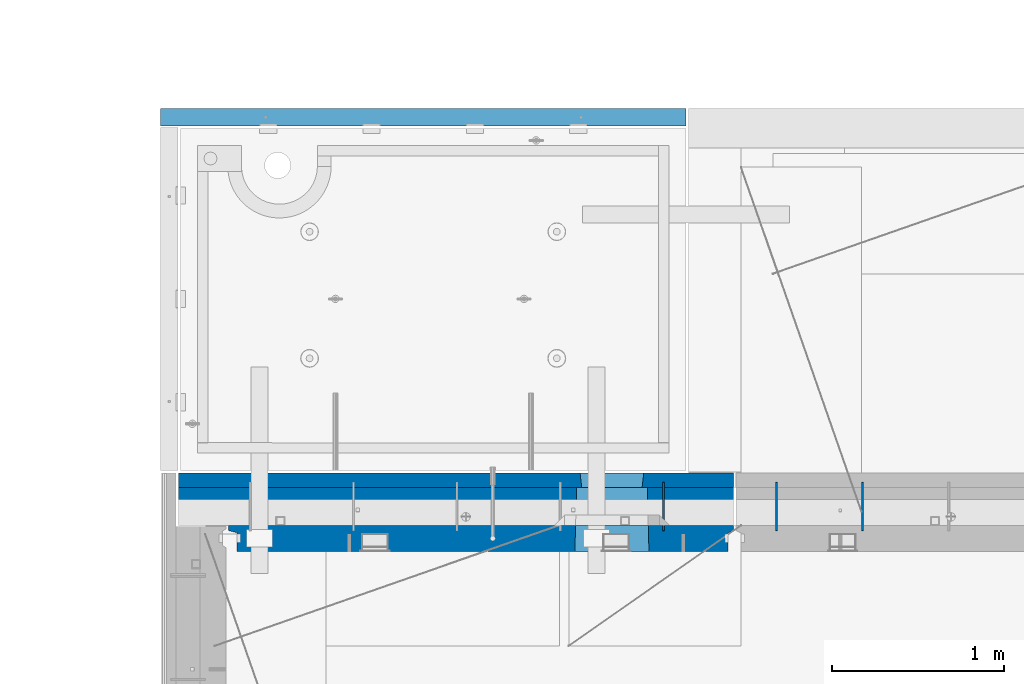
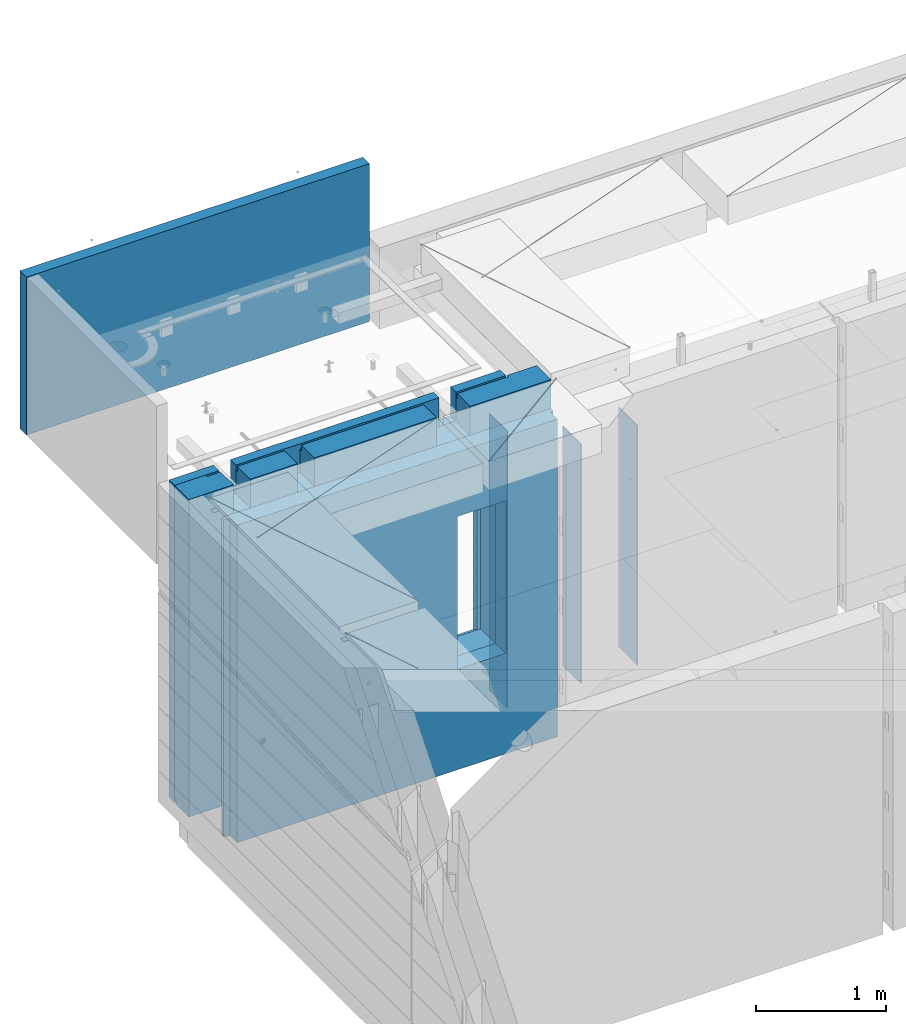
# One storey, part 215 of 325: 7 walls, 3 elements without a shape of their own.
"""IFC2X3 building model written with IfcOpenShell, lengths in millimetres."""

from ifc_helpers import new_model, si_unit, frame, origin_with_axes, place, context, subcontext, project, spatial, faceted_brep, material, type_object, element, aggregate, save


model = new_model("IFC2X3")

# Units and contexts
model_context = context("Model", 3, precision=1e-05, world=origin_with_axes())
body_context = subcontext(model_context, "Body", "Model", "MODEL_VIEW")
ifc_project = project(units=[si_unit("LENGTHUNIT", "METRE", prefix="MILLI"), si_unit("AREAUNIT", "SQUARE_METRE"), si_unit("VOLUMEUNIT", "CUBIC_METRE"), si_unit("MASSUNIT", "GRAM", prefix="KILO"), si_unit("TIMEUNIT", "SECOND"), si_unit("PLANEANGLEUNIT", "RADIAN"), si_unit("SOLIDANGLEUNIT", "STERADIAN"), si_unit("THERMODYNAMICTEMPERATUREUNIT", "DEGREE_CELSIUS"), si_unit("LUMINOUSINTENSITYUNIT", "LUMEN")], contexts=[model_context])

# Site, building, storey
site_placement = place(None, origin_with_axes())
site = spatial("IfcSite", under=ifc_project, at=site_placement, CompositionType="ELEMENT")
building_placement = place(site_placement, origin_with_axes())
building = spatial("IfcBuilding", under=site, at=building_placement, CompositionType="ELEMENT")
storey_placement = place(building_placement, origin_with_axes())
storey = spatial("IfcBuildingStorey", under=building, at=storey_placement, Name="1", CompositionType="ELEMENT", Elevation=0.0)

# Assembly, walls
assembly_1_placement = place(storey_placement, origin_with_axes())
assembly_1 = element("IfcElementAssembly", 1, at=assembly_1_placement, inside=storey, AssemblyPlace="NOTDEFINED", PredefinedType="REINFORCEMENT_UNIT")
ifc_material_1 = material(Name="Undefined")
wall_type_1 = type_object("IfcWallType", PredefinedType="NOTDEFINED")
wall_1_placement = place(assembly_1_placement, frame((10540.0002441406, 20549.9951872276, 83115.0), z_axis=(0.0, 0.0, 1.0), x_axis=(0.0, 1.0, 0.0)))
wall_1 = element("IfcWall", 2, at=wall_1_placement, type_object=wall_type_1, material=ifc_material_1, Name="(PD)", context=body_context, shape_type="Brep", body=[
    faceted_brep([(0.0, 5.0, -1300.0), (0.0, 5.0, 1300.0), (280.0, 5.0, 1300.0), (280.0, 5.0, -1300.0), (0.0, -5.0, 1300.0), (280.0, -5.0, 1300.0), (0.0, -5.0, -1300.0), (280.0, -5.0, -1300.0)], [[[0, 1, 2, 3]], [[1, 4, 5, 2]], [[4, 6, 7, 5]], [[6, 0, 3, 7]], [[5, 7, 3, 2]], [[6, 4, 1, 0]]]),
])
ifc_material_2 = material(Name="COS5gt")
wall_type_2 = type_object("IfcWallType", PredefinedType="NOTDEFINED")
wall_2_placement = place(assembly_1_placement, frame((7725.0, 20689.9951872276, 83247.5), z_axis=(0.0, 0.0, 1.0), x_axis=(1.0, 0.0, 0.0)))
wall_2 = element("IfcWall", 3, at=wall_2_placement, type_object=wall_type_2, material=ifc_material_2, context=body_context, shape_type="Brep", body=[
    faceted_brep([(964.999999999998, 110.0, 1442.5), (964.999999999998, 90.0, 1442.5), (964.999999999998, 90.0, 1492.5), (964.999999999998, -110.0, 1492.5), (964.999999999998, -110.000000000007, 1222.5), (964.999999999998, 109.999999999993, 1222.5), (1115.0, -110.000000000007, 1222.5), (1115.0, 109.999999999993, 1222.5), (1115.0, 110.0, 1442.5), (1115.0, -110.0, 1492.5), (1115.0, 90.0, 1492.5), (1115.0, 90.0, 1442.5), (2304.0538236821, -110.000000000007, 613.445945945947), (2309.99976962805, 110.0, 607.5), (2719.99976962805, 110.0, 607.5), (2725.94571557399, -110.000000000007, 613.445945945947), (2309.99976962805, 110.0, -802.5), (2304.0538236821, -110.000000000007, -813.445945945947), (2309.99976962805, 110.0, -807.5), (2725.94571557399, -110.000000000007, -813.445945945947), (2719.99976962805, 110.0, -807.5), (2689.99976962805, 110.0, -807.5), (2339.99976962805, 110.0, -807.5), (2719.99976962805, 110.0, -802.5), (3220.0, 90.0, -1492.5), (0.0, 90.0, -1492.5), (0.0, 90.0, -1442.5), (3220.0, 90.0, -1442.5), (3220.0, -110.0, -1492.5), (0.0, -110.0, -1492.5), (274.0, 110.0, 1442.5), (274.0, 90.0, 1442.5), (394.999999999998, 90.0, 1442.5), (394.999999999998, 110.0, 1442.5), (274.0, 110.0, 1492.5), (274.0, 90.0, 1492.5), (394.999999999998, 90.0, 1492.5), (544.999999999998, 110.0, 1442.5), (544.999999999998, 90.0, 1442.5), (544.999999999998, 90.0, 1492.5), (544.999999999998, -110.0, 1492.5), (544.999999999998, 109.999999999996, 1222.5), (544.999999999998, -110.0, 1222.5), (394.999999999998, 109.999999999996, 1222.5), (394.999999999998, -110.0, 1222.5), (394.999999999998, -110.0, 1492.5), (0.0, 110.0, 1492.5), (0.0, -110.0, 1492.5), (0.0, 110.0, -1442.5), (3220.0, 110.0, -1442.5), (3220.0, 90.0, 857.600000000006), (2945.00000000005, 90.0, 857.600000000006), (2945.00000000005, 90.0, 907.600000000006), (3220.0, 90.0, 907.600000000006), (3220.0, 110.0, 857.600000000006), (2945.00000000005, 110.0, 857.600000000006), (2945.00000000005, 110.0, 907.600000000006), (3220.0, 110.0, 907.600000000006), (3220.0, 110.0, 1492.5), (3220.0, -110.0, 1492.5), (2960.0, 110.0, 1492.5), (2960.0, 90.0, 1492.5), (2500.0, 90.0, 1492.5), (2500.0, -110.0, 1492.5), (2960.0, 110.0, 1442.5), (2960.0, 90.0, 1442.5), (2500.0, 110.0, 1442.5), (2500.0, 90.0, 1442.5), (2500.0, 109.999999999996, 1222.5), (2500.0, -110.000000000004, 1222.5), (2350.0, 109.999999999996, 1222.5), (2350.0, -110.000000000004, 1222.5), (2200.0, 109.999999999996, 1222.5), (2200.0, -110.000000000007, 1222.5), (2200.0, 110.0, 1442.5), (2200.0, 90.0, 1442.5), (2200.0, 90.0, 1492.5), (2200.0, -110.0, 1492.5), (588.089351658544, -110.000000000007, -905.177669529658), (579.978767938008, -110.000000000007, -910.596988312784), (570.411682128881, -110.000000000007, -912.5), (560.844596319754, -110.000000000007, -910.596988312784), (552.734012599218, -110.000000000007, -905.177669529658), (547.314693816099, -110.000000000007, -897.067085809133), (545.411682128881, -110.000000000007, -887.5), (547.314693816099, -110.000000000007, -877.932914190867), (552.734012599218, -110.000000000007, -869.822330470342), (560.844596319754, -110.000000000007, -864.403011687216), (570.411682128881, -110.000000000007, -862.5), (579.978767938008, -110.000000000007, -864.403011687216), (588.089351658544, -110.000000000007, -869.822330470342), (593.508670441663, -110.000000000007, -877.932914190867), (595.411682128881, -110.000000000007, -887.5), (593.508670441663, -110.000000000007, -897.067085809133), (593.508670441663, 109.999999999996, -897.067085809133), (595.411682128881, 109.999999999996, -887.5), (588.089351658544, 109.999999999996, -905.177669529658), (579.978767938008, 109.999999999996, -910.596988312784), (570.411682128881, 109.999999999996, -912.5), (560.844596319754, 109.999999999996, -910.596988312784), (552.734012599218, 109.999999999996, -905.177669529658), (547.314693816099, 109.999999999996, -897.067085809133), (545.411682128881, 109.999999999996, -887.5), (547.314693816099, 109.999999999996, -877.932914190867), (552.734012599218, 109.999999999996, -869.822330470342), (560.844596319754, 109.999999999996, -864.403011687216), (570.411682128881, 109.999999999996, -862.5), (579.978767938008, 109.999999999996, -864.403011687216), (588.089351658544, 109.999999999996, -869.822330470342), (593.508670441663, 109.999999999996, -877.932914190867)], [[[0, 1, 2, 3, 4, 5]], [[5, 4, 6, 7]], [[8, 7, 6, 9, 10, 11]], [[12, 13, 14, 15]], [[16, 13, 12, 17, 18]], [[19, 20, 21, 22, 18, 17]], [[15, 14, 23, 20, 19]], [[24, 25, 26, 27]], [[28, 29, 25, 24]], [[30, 31, 32, 33]], [[34, 35, 31, 30]], [[31, 35, 36, 32]], [[37, 38, 1, 0]], [[39, 40, 3, 2]], [[38, 39, 2, 1]], [[37, 41, 42, 40, 39, 38]], [[43, 44, 42, 41]], [[33, 32, 36, 45, 44, 43]], [[35, 34, 46, 47, 45, 36]], [[25, 29, 47, 46, 48, 26]], [[49, 27, 26, 48]], [[50, 51, 52, 53]], [[54, 55, 51, 50]], [[56, 52, 51, 55]], [[57, 53, 52, 56]], [[58, 59, 28, 24, 27, 49, 54, 50, 53, 57]], [[59, 58, 60, 61, 62, 63]], [[60, 64, 65, 61]], [[65, 64, 66, 67]], [[61, 65, 67, 62]], [[66, 68, 69, 63, 62, 67]], [[69, 68, 70, 71]], [[70, 72, 73, 71]], [[74, 75, 76, 77, 73, 72]], [[75, 74, 8, 11]], [[76, 75, 11, 10]], [[77, 76, 10, 9]], [[4, 3, 40, 42, 44, 45, 47, 29, 28, 59, 63, 69, 71, 73, 77, 9, 6], [78, 79, 80, 81, 82, 83, 84, 85, 86, 87, 88, 89, 90, 91, 92, 93], [17, 12, 15, 19]], [[94, 93, 92, 95]], [[96, 78, 93, 94]], [[97, 79, 78, 96]], [[98, 80, 79, 97]], [[99, 81, 80, 98]], [[100, 82, 81, 99]], [[101, 83, 82, 100]], [[102, 84, 83, 101]], [[103, 85, 84, 102]], [[104, 86, 85, 103]], [[105, 87, 86, 104]], [[106, 88, 87, 105]], [[107, 89, 88, 106]], [[108, 90, 89, 107]], [[109, 91, 90, 108]], [[95, 92, 91, 109]], [[74, 72, 70, 68, 66, 64, 60, 58, 57, 56, 55, 54, 49, 48, 46, 34, 30, 33, 43, 41, 37, 0, 5, 7, 8], [108, 107, 106, 105, 104, 103, 102, 101, 100, 99, 98, 97, 96, 94, 95, 109], [16, 18, 22, 21, 20, 23, 14, 13]]]),
])
ifc_material_3 = material(Name="CONCRETE/C30/37")
wall_type_3 = type_object("IfcWallType", PredefinedType="NOTDEFINED")
wall_3_placement = place(assembly_1_placement, frame((7725.0, 20842.4951872276, 83247.5), z_axis=(0.0, 0.0, 1.0), x_axis=(1.0, 0.0, 0.0)))
wall_3 = element("IfcWall", 4, at=wall_3_placement, type_object=wall_type_3, material=ifc_material_3, context=body_context, shape_type="Brep", body=[
    faceted_brep([(593.508670441663, 42.5000000208493, -877.932914190867), (593.508670441663, -42.5, -877.932914190867), (588.089351658544, -42.5, -869.822330470342), (588.089351658544, 42.5000000431755, -869.822330470342), (579.978767938008, -42.5, -864.403011687216), (579.978767938008, 42.5000000592008, -864.403011687216), (570.411682128881, -42.5, -862.5), (570.411682128881, 42.5000000664877, -862.5), (560.844596319754, -42.5, -864.403011687216), (560.844596319754, 42.5000000639229, -864.403011687216), (552.734012599218, -42.5, -869.822330470342), (552.734012599218, 42.500000051903, -869.822330470342), (547.314693816099, -42.5, -877.932914190867), (547.314693816099, 42.5000000322543, -877.932914190867), (545.411682128881, -42.5, -887.5), (545.411682128881, 42.5000000079635, -887.5), (546.903524804578, 32.4999991126897, -894.999999599575), (546.505700171499, 42.4999998715466, -893.000000110755), (547.314693816099, -42.5, -897.067085809133), (547.314693816099, 32.4999991412187, -897.067085809133), (552.734012599218, -42.5, -905.177669529658), (552.734012599218, 32.4999992507037, -905.000000000757), (555.461322965299, 42.4999998787862, -907.000000055239), (560.844596319754, -42.5, -910.596988312784), (560.844596319754, 42.4999998857165, -910.596988312784), (570.411682128881, -42.5, -912.5), (570.411682128881, 42.4999998831663, -912.5), (579.978767938008, -42.5, -910.596988312784), (579.978767938008, 42.4999998813801, -910.596988312784), (585.362041292479, 42.4999998722597, -907.000000055239), (588.089351658544, -42.5, -905.177669529658), (588.089351658544, 32.4999992507037, -905.000000000757), (593.508670441663, -42.5, -897.067085809133), (593.508670441663, 32.4999991412187, -897.067085809133), (594.317664086262, 42.4999998603089, -893.000000110755), (593.919839453183, 32.4999991126897, -894.999999599575), (595.411682128881, -42.5, -887.5), (595.411682128881, 42.4999999956199, -887.5), (2350.0, 32.4999992507001, 1344.99999999924), (544.999999999998, 32.4999992507001, 1344.99999999924), (544.999999999998, 32.4999991126897, 1355.00000040043), (2350.0, 32.4999991126897, 1355.00000040043), (2350.0, 42.4999999999964, 1342.99999994476), (544.999999999998, 42.5, 1342.99999994476), (0.0, 42.5, 1492.5), (394.999999999998, 42.5, 1492.5), (394.999999999998, 42.4999992431585, 1356.99999988925), (0.0, 42.5, 1356.99999988925), (0.0, -42.5, 1492.5), (394.999999999998, -42.5, 1492.5), (394.999999999998, -42.5, 1222.5), (394.999999999998, 42.5, 1222.5), (394.999999999998, 42.5, 1342.99999994476), (394.999999999998, 32.4999992507001, 1344.99999999924), (394.999999999998, 32.4999991126897, 1355.00000040043), (544.999999999998, -42.5, 1222.5), (544.999999999998, 42.5, 1222.5), (544.999999999998, 42.5, 1492.5), (544.999999999998, -42.5, 1492.5), (2350.0, -42.5, 1492.5), (2350.0, 42.5, 1492.5), (2350.0, 42.4999992431585, 1356.99999988925), (544.999999999998, 42.5, 1356.99999988925), (2350.0, -42.5000000000036, 1222.5), (2350.0, 42.4999999999964, 1222.5), (2500.0, -42.5000000000036, 1222.5), (2500.0, 42.4999999999964, 1222.5), (2500.0, 42.5, 1492.5), (2500.0, -42.5, 1492.5), (2945.0, -42.5, 1492.5), (2945.0, 42.5, 1492.5), (3220.0, 42.5, 857.5), (2945.0, 42.4999999999964, 857.5), (2945.0, -42.5000000000073, 857.5), (3220.0, -42.5, 857.5), (0.0, -42.5, -1492.5), (0.0, 42.5, -1492.5), (3220.0, 42.5, -1492.5), (3220.0, -42.5, -1492.5), (0.0, 42.5, -1357.00000005524), (3220.0, 42.5, -1357.00000005524), (0.0, 32.4999992507037, -1355.00000000074), (3220.0, 32.4999992507037, -1355.00000000076), (0.0, 32.4999991127006, -1344.99999959956), (3220.0, 32.4999991126897, -1344.99999959957), (3220.0, 42.4999992431585, -1343.00000011075), (0.0, 42.5, -1343.00000011075), (0.0, 42.5, -1207.00000005524), (3220.0, 42.499999289932, -1207.00000005524), (0.0, 32.4999992507037, -1205.00000000074), (3220.0, 32.4999992507037, -1205.00000000076), (0.0, 32.4999991127006, -1194.99999959956), (3220.0, 32.4999991126897, -1194.99999959957), (3220.0, 42.4999992431585, -1193.00000011075), (0.0, 42.5, -1193.00000011075), (0.0, 42.5, -1057.00000005524), (3220.0, 42.499999293359, -1057.00000005524), (0.0, 32.4999992507037, -1055.00000000074), (3220.0, 32.4999992507037, -1055.00000000076), (0.0, 32.4999991127006, -1044.99999959956), (3220.0, 32.4999991126897, -1044.99999959957), (3220.0, 42.4999992431585, -1043.00000011075), (0.0, 42.5, -1043.00000011075), (0.0, 32.4999992507037, -905.000000000742), (0.0, 32.4999991127006, -894.99999959956), (0.0, 42.5, -907.000000055239), (3220.0, 42.4999992973171, -907.000000055239), (3220.0, 32.4999992507037, -905.000000000757), (3220.0, 32.4999991126897, -894.999999599575), (3220.0, 42.4999992431585, -893.000000110755), (3220.0, 42.4999993019592, -757.000000055239), (3220.0, 32.4999992507037, -755.000000000757), (3220.0, 32.4999991126897, -744.999999599575), (3220.0, 42.4999992431585, -743.000000110755), (3220.0, 42.4999993074707, -607.000000055239), (3220.0, 32.4999992507037, -605.000000000757), (3220.0, 32.4999991126897, -594.999999599575), (3220.0, 42.4999992431585, -593.000000110755), (3220.0, 42.4999993141209, -457.000000055239), (3220.0, 32.4999992507037, -455.000000000757), (3220.0, 32.4999991126897, -444.999999599575), (3220.0, 42.4999992431585, -443.000000110755), (3220.0, 42.4999993223028, -307.000000055239), (3220.0, 32.4999992507037, -305.000000000757), (3220.0, 32.4999991126897, -294.999999599575), (3220.0, 42.4999992431585, -293.000000110755), (3220.0, 42.4999993326237, -157.000000055239), (3220.0, 32.4999992507037, -155.000000000757), (3220.0, 32.4999991126897, -144.999999599575), (3220.0, 42.4999992431585, -143.000000110755), (3220.0, 42.4999993460369, -7.00000005523907), (3220.0, 32.4999992507037, -5.0000000007567), (3220.0, 32.4999991126897, 5.00000040042505), (3220.0, 42.4999992431585, 6.99999988924537), (3220.0, 42.4999993641832, 142.999999944761), (3220.0, 32.4999992507037, 144.999999999243), (3220.0, 32.4999991126897, 155.000000400425), (3220.0, 42.4999992431585, 156.999999889245), (3220.0, 42.4999993900965, 292.999999944761), (3220.0, 32.4999992507037, 294.999999999243), (3220.0, 32.4999991126897, 305.000000400425), (3220.0, 42.4999992431585, 306.999999889245), (3220.0, 42.4999994301324, 442.999999944761), (3220.0, 32.4999992507037, 444.999999999243), (3220.0, 32.4999991126897, 455.000000400425), (3220.0, 42.4999992431585, 456.999999889245), (3220.0, 42.4999995001635, 592.999999944761), (3220.0, 32.4999992507037, 594.999999999243), (3220.0, 32.4999991126897, 605.000000400425), (3220.0, 42.4999992431585, 606.999999889245), (3220.0, 42.4999996540573, 742.999999944761), (3220.0, 32.4999992507037, 744.999999999243), (3220.0, 32.4999991126897, 755.000000400425), (3220.0, 42.4999992431585, 756.999999889245), (2339.99976962805, 42.5, 582.5), (2689.99976962805, 42.5, 582.5), (2699.99976962805, 42.5, 582.5), (2689.99976962805, -42.5, 587.5), (2339.99976962805, -42.5, 587.5), (2329.99976962805, 42.5, 582.5), (2329.99976962805, 42.5, -857.5), (2339.99976962805, -42.5, -807.5), (2689.99976962805, -42.5, -807.5), (2699.99976962805, 42.5, -857.5), (2339.99976962805, -42.5, 582.5), (2329.99976962805, 42.5, -757.000000055239), (2331.17624030443, 32.4999992507037, -755.000000000757), (2331.17624032067, 32.4999991126897, -744.999999599575), (2329.99976962805, 42.5, -743.000000110755), (2329.99976962805, 42.5, -607.000000055239), (2331.17624030444, 32.4999992507037, -605.000000000757), (2331.17624032067, 32.4999991126897, -594.999999599575), (2329.99976962805, 42.5, -593.000000110755), (2329.99976962805, 42.5, -457.000000055239), (2331.17624030443, 32.4999992507037, -455.000000000757), (2331.17624032067, 32.4999991126897, -444.999999599575), (2329.99976962805, 42.5, -443.000000110755), (2329.99976962805, 42.5, -307.000000055239), (2331.17624030443, 32.4999992507037, -305.000000000757), (2331.17624032067, 32.4999991126897, -294.999999599575), (2329.99976962805, 42.5, -293.000000110755), (2329.99976962805, 42.5, -157.000000055239), (2331.17624030443, 32.4999992507037, -155.000000000757), (2331.17624032067, 32.4999991126897, -144.999999599575), (2329.99976962805, 42.5, -143.000000110755), (2329.99976962805, 42.5, -7.00000005523907), (2331.17624030443, 32.4999992507037, -5.0000000007567), (2331.17624032067, 32.4999991126897, 5.00000040042505), (2329.99976962805, 42.5, 6.99999988924537), (2329.99976962805, 42.5, 142.999999944761), (2331.17624030443, 32.4999992507037, 144.999999999243), (2331.17624032067, 32.4999991126897, 155.000000400425), (2329.99976962805, 42.5, 156.999999889245), (2329.99976962805, 42.5, 292.999999944761), (2331.17624030443, 32.4999992507037, 294.999999999243), (2331.17624032067, 32.4999991126897, 305.000000400425), (2329.99976962805, 42.5, 306.999999889245), (2329.99976962805, 42.5, 442.999999944761), (2331.17624030444, 32.4999992507037, 444.999999999243), (2331.17624032067, 32.4999991126897, 455.000000400425), (2329.99976962805, 42.5, 456.999999889245), (0.0, 42.5, -757.000000055239), (0.0, 32.4999992507037, -755.000000000742), (0.0, 32.4999991127006, -744.99999959956), (0.0, 42.5, -743.000000110755), (0.0, 42.5, -607.000000055239), (3.63797880709171e-12, 32.4999992507037, -605.000000000742), (3.63797880709171e-12, 32.4999991127006, -594.99999959956), (0.0, 42.5, -593.000000110755), (0.0, 42.5, -457.000000055239), (0.0, 32.4999992507037, -455.000000000742), (0.0, 32.4999991127006, -444.99999959956), (0.0, 42.5, -443.000000110755), (0.0, 42.5, -307.000000055239), (0.0, 32.4999992507037, -305.000000000742), (0.0, 32.4999991127006, -294.99999959956), (0.0, 42.5, -293.000000110755), (0.0, 42.5, -157.000000055239), (3.63797880709171e-12, 32.4999992507037, -155.000000000742), (3.63797880709171e-12, 32.4999991127006, -144.99999959956), (0.0, 42.5, -143.000000110755), (0.0, 42.5, -7.00000005523907), (0.0, 32.4999992507037, -5.00000000074215), (0.0, 32.4999991127006, 5.0000004004396), (0.0, 42.5, 6.99999988924537), (0.0, 42.5, 142.999999944761), (-3.63797880709171e-12, 32.4999992507037, 144.999999999258), (-3.63797880709171e-12, 32.4999991127006, 155.00000040044), (0.0, 42.5, 156.999999889245), (0.0, 42.5, 292.999999944761), (-3.63797880709171e-12, 32.4999992507037, 294.999999999258), (-3.63797880709171e-12, 32.4999991127006, 305.00000040044), (0.0, 42.5, 306.999999889245), (0.0, 42.5, 442.999999944761), (0.0, 32.4999992507037, 444.999999999258), (0.0, 32.4999991127006, 455.00000040044), (0.0, 42.5, 456.999999889245), (2699.99976962805, 42.5, 456.999999889245), (0.0, 42.5, 592.999999944761), (3.63797880709171e-12, 32.4999992507037, 594.999999999258), (3.63797880709171e-12, 32.4999991127006, 605.00000040044), (0.0, 42.5, 606.999999889245), (0.0, 42.5, 742.999999944761), (0.0, 32.4999992507037, 744.999999999258), (0.0, 32.4999991127006, 755.00000040044), (0.0, 42.5, 756.999999889245), (0.0, 42.5, 892.999999944761), (2945.0, 42.4999999999964, 892.999999944761), (0.0, 32.4999992507037, 894.999999999258), (2945.0, 32.4999992507037, 894.999999999243), (0.0, 32.4999991127006, 905.00000040044), (2945.0, 32.4999991126897, 905.000000400425), (2945.0, 42.4999992431585, 906.999999889245), (0.0, 42.5, 906.999999889245), (0.0, 42.5, 1042.99999994476), (2945.0, 42.4999994189602, 1042.99999994476), (0.0, 32.4999992507037, 1044.99999999926), (2945.0, 32.4999992507037, 1044.99999999924), (0.0, 32.4999991127006, 1055.00000040044), (2945.0, 32.4999991126897, 1055.00000040043), (2945.0, 42.4999992431585, 1056.99999988925), (0.0, 42.5, 1056.99999988925), (0.0, 42.5, 1192.99999994476), (2945.0, 42.4999994795071, 1192.99999994476), (0.0, 32.4999992507037, 1194.99999999926), (2945.0, 32.4999992507037, 1194.99999999924), (0.0, 32.4999991127006, 1205.00000040044), (2945.0, 32.4999991126897, 1205.00000040043), (2945.0, 42.4999992431585, 1206.99999988925), (0.0, 42.5, 1206.99999988925), (2945.0, 42.4999996036822, 1342.99999994476), (2945.0, 32.4999992507001, 1344.99999999924), (2945.0, 32.4999991126897, 1355.00000040043), (2945.0, 42.4999992431585, 1356.99999988925), (2500.0, 42.4999999999964, 1356.99999988925), (2500.0, 32.4999992507001, 1344.99999999924), (2500.0, 42.4999999999964, 1342.99999994476), (2500.0, 32.4999991126897, 1355.00000040043), (0.0, 42.5, 1342.99999994476), (-3.63797880709171e-12, 32.4999992507037, 1344.99999999926), (-3.63797880709171e-12, 32.4999991127006, 1355.00000040044), (0.0, 42.5, -893.000000110755), (2699.99976962805, 42.5, -757.000000055239), (2698.82329895166, 32.4999992507037, -755.000000000757), (2698.82329893542, 32.4999991126897, -744.999999599575), (2699.99976962805, 42.5, -743.000000110755), (2699.99976962805, 42.5, -607.000000055239), (2698.82329895166, 32.4999992507037, -605.000000000757), (2698.82329893543, 32.4999991126897, -594.999999599575), (2699.99976962805, 42.5, -593.000000110755), (2699.99976962805, 42.5, -457.000000055239), (2698.82329895166, 32.4999992507037, -455.000000000757), (2698.82329893543, 32.4999991126897, -444.999999599575), (2699.99976962805, 42.5, -443.000000110755), (2699.99976962805, 42.5, -307.000000055239), (2698.82329895167, 32.4999992507037, -305.000000000757), (2698.82329893543, 32.4999991126897, -294.999999599575), (2699.99976962805, 42.5, -293.000000110755), (2699.99976962805, 42.5, -157.000000055239), (2698.82329895167, 32.4999992507037, -155.000000000757), (2698.82329893543, 32.4999991126897, -144.999999599575), (2699.99976962805, 42.5, -143.000000110755), (2699.99976962805, 42.5, -7.00000005523907), (2698.82329895166, 32.4999992507037, -5.0000000007567), (2698.82329893543, 32.4999991126897, 5.00000040042505), (2699.99976962805, 42.5, 6.99999988924537), (2699.99976962805, 42.5, 142.999999944761), (2698.82329895167, 32.4999992507037, 144.999999999243), (2698.82329893543, 32.4999991126897, 155.000000400425), (2699.99976962805, 42.5, 156.999999889245), (2699.99976962805, 42.5, 292.999999944761), (2698.82329895166, 32.4999992507037, 294.999999999243), (2698.82329893542, 32.4999991126897, 305.000000400425), (2699.99976962805, 42.5, 306.999999889245), (2699.99976962805, 42.5, 442.999999944761), (2698.82329895167, 32.4999992507037, 444.999999999243), (2698.82329893543, 32.4999991126897, 455.000000400425), (2689.99976962805, -42.5, 582.5)], [[[0, 1, 2, 3]], [[3, 2, 4, 5]], [[5, 4, 6, 7]], [[7, 6, 8, 9]], [[9, 8, 10, 11]], [[11, 10, 12, 13]], [[13, 12, 14, 15]], [[16, 17, 15, 14, 18, 19]], [[19, 18, 20, 21]], [[22, 21, 20, 23, 24]], [[24, 23, 25, 26]], [[26, 25, 27, 28]], [[29, 28, 27, 30, 31]], [[31, 30, 32, 33]], [[34, 35, 33, 32, 36, 37]], [[37, 36, 1, 0]], [[38, 39, 40, 41]], [[42, 43, 39, 38]], [[44, 45, 46, 47]], [[44, 48, 49, 45]], [[45, 49, 50, 51, 52, 53, 54, 46]], [[51, 50, 55, 56]], [[57, 58, 59, 60]], [[57, 60, 61, 62]], [[39, 43, 56, 55, 58, 57, 62, 40]], [[61, 41, 40, 62]], [[60, 59, 63, 64, 42, 38, 41, 61]], [[64, 63, 65, 66]], [[67, 68, 69, 70]], [[71, 72, 73, 74]], [[75, 76, 77, 78]], [[77, 76, 79, 80]], [[80, 79, 81, 82]], [[82, 81, 83, 84]], [[85, 84, 83, 86]], [[85, 86, 87, 88]], [[88, 87, 89, 90]], [[90, 89, 91, 92]], [[93, 92, 91, 94]], [[93, 94, 95, 96]], [[96, 95, 97, 98]], [[98, 97, 99, 100]], [[101, 100, 99, 102]], [[103, 104, 16, 19, 21]], [[105, 103, 21, 22]], [[106, 101, 102, 105, 22, 24, 26, 28, 29]], [[107, 106, 29, 31]], [[108, 107, 31, 33, 35]], [[109, 108, 35, 34]], [[71, 74, 78, 77, 80, 82, 84, 85, 88, 90, 92, 93, 96, 98, 100, 101, 106, 107, 108, 109, 110, 111, 112, 113, 114, 115, 116, 117, 118, 119, 120, 121, 122, 123, 124, 125, 126, 127, 128, 129, 130, 131, 132, 133, 134, 135, 136, 137, 138, 139, 140, 141, 142, 143, 144, 145, 146, 147, 148, 149, 150, 151, 152, 153]], [[154, 155, 156, 157, 158, 159]], [[160, 161, 162, 163]], [[159, 158, 164, 161, 160, 165, 166, 167, 168, 169, 170, 171, 172, 173, 174, 175, 176, 177, 178, 179, 180, 181, 182, 183, 184, 185, 186, 187, 188, 189, 190, 191, 192, 193, 194, 195, 196, 197, 198, 199, 200]], [[165, 201, 202, 166]], [[166, 202, 203, 167]], [[167, 203, 204, 168]], [[168, 204, 205, 169]], [[169, 205, 206, 170]], [[170, 206, 207, 171]], [[171, 207, 208, 172]], [[172, 208, 209, 173]], [[173, 209, 210, 174]], [[174, 210, 211, 175]], [[175, 211, 212, 176]], [[176, 212, 213, 177]], [[177, 213, 214, 178]], [[178, 214, 215, 179]], [[179, 215, 216, 180]], [[180, 216, 217, 181]], [[181, 217, 218, 182]], [[182, 218, 219, 183]], [[183, 219, 220, 184]], [[184, 220, 221, 185]], [[185, 221, 222, 186]], [[186, 222, 223, 187]], [[187, 223, 224, 188]], [[188, 224, 225, 189]], [[189, 225, 226, 190]], [[190, 226, 227, 191]], [[191, 227, 228, 192]], [[192, 228, 229, 193]], [[193, 229, 230, 194]], [[194, 230, 231, 195]], [[195, 231, 232, 196]], [[196, 232, 233, 197]], [[197, 233, 234, 198]], [[198, 234, 235, 199]], [[199, 235, 236, 200]], [[145, 237, 156, 155, 154, 159, 200, 236, 238, 146]], [[146, 238, 239, 147]], [[147, 239, 240, 148]], [[149, 148, 240, 241]], [[149, 241, 242, 150]], [[150, 242, 243, 151]], [[151, 243, 244, 152]], [[153, 152, 244, 245]], [[72, 71, 153, 245, 246, 247]], [[247, 246, 248, 249]], [[249, 248, 250, 251]], [[252, 251, 250, 253]], [[252, 253, 254, 255]], [[255, 254, 256, 257]], [[257, 256, 258, 259]], [[260, 259, 258, 261]], [[260, 261, 262, 263]], [[263, 262, 264, 265]], [[265, 264, 266, 267]], [[268, 267, 266, 269]], [[70, 69, 73, 72, 247, 249, 251, 252, 255, 257, 259, 260, 263, 265, 267, 268, 270, 271, 272, 273]], [[67, 70, 273, 274]], [[275, 276, 66, 65, 68, 67, 274, 277]], [[273, 272, 277, 274]], [[271, 275, 277, 272]], [[270, 276, 275, 271]], [[268, 269, 278, 52, 51, 56, 43, 42, 64, 66, 276, 270]], [[52, 278, 279, 53]], [[53, 279, 280, 54]], [[46, 54, 280, 47]], [[279, 278, 269, 266, 264, 262, 261, 258, 256, 254, 253, 250, 248, 246, 245, 244, 243, 242, 241, 240, 239, 238, 236, 235, 234, 233, 232, 231, 230, 229, 228, 227, 226, 225, 224, 223, 222, 221, 220, 219, 218, 217, 216, 215, 214, 213, 212, 211, 210, 209, 208, 207, 206, 205, 204, 203, 202, 201, 281, 104, 103, 105, 102, 99, 97, 95, 94, 91, 89, 87, 86, 83, 81, 79, 76, 75, 48, 44, 47, 280]], [[104, 281, 17, 16]], [[3, 5, 7, 9, 11, 13, 15, 17, 281, 201, 165, 160, 163, 282, 110, 109, 34, 37, 0]], [[110, 282, 283, 111]], [[111, 283, 284, 112]], [[113, 112, 284, 285]], [[113, 285, 286, 114]], [[114, 286, 287, 115]], [[115, 287, 288, 116]], [[117, 116, 288, 289]], [[117, 289, 290, 118]], [[118, 290, 291, 119]], [[119, 291, 292, 120]], [[121, 120, 292, 293]], [[121, 293, 294, 122]], [[122, 294, 295, 123]], [[123, 295, 296, 124]], [[125, 124, 296, 297]], [[125, 297, 298, 126]], [[126, 298, 299, 127]], [[127, 299, 300, 128]], [[129, 128, 300, 301]], [[129, 301, 302, 130]], [[130, 302, 303, 131]], [[131, 303, 304, 132]], [[133, 132, 304, 305]], [[133, 305, 306, 134]], [[134, 306, 307, 135]], [[135, 307, 308, 136]], [[137, 136, 308, 309]], [[137, 309, 310, 138]], [[138, 310, 311, 139]], [[139, 311, 312, 140]], [[141, 140, 312, 313]], [[141, 313, 314, 142]], [[142, 314, 315, 143]], [[143, 315, 316, 144]], [[145, 144, 316, 237]], [[315, 314, 313, 312, 311, 310, 309, 308, 307, 306, 305, 304, 303, 302, 301, 300, 299, 298, 297, 296, 295, 294, 293, 292, 291, 290, 289, 288, 287, 286, 285, 284, 283, 282, 163, 162, 317, 157, 156, 237, 316]], [[69, 68, 65, 63, 59, 58, 55, 50, 49, 48, 75, 78, 74, 73], [30, 27, 25, 23, 20, 18, 14, 12, 10, 8, 6, 4, 2, 1, 36, 32], [162, 161, 164, 158, 157, 317]]]),
])
ifc_material_4 = material(Name="CONCRETE/C25/30")
wall_type_4 = type_object("IfcWallType", PredefinedType="NOTDEFINED")
wall_4_placement = place(assembly_1_placement, frame((8000.0, 20504.9951872276, 82977.5), z_axis=(0.0, 0.0, 1.0), x_axis=(1.0, 0.0, 0.0)))
wall_4 = element("IfcWall", 5, at=wall_4_placement, type_object=wall_type_4, material=ifc_material_4, context=body_context, shape_type="Brep", body=[
    faceted_brep([(318.508670441663, 75.0, -607.932914190867), (318.508670441663, -75.0, -607.932914190867), (313.089351658544, -75.0, -599.822330470342), (313.089351658544, 75.0, -599.822330470342), (304.978767938008, -75.0, -594.403011687216), (304.978767938008, 75.0, -594.403011687216), (295.411682128881, -75.0, -592.5), (295.411682128881, 75.0, -592.5), (285.844596319754, -75.0, -594.403011687216), (285.844596319754, 75.0, -594.403011687216), (277.734012599218, -75.0, -599.822330470342), (277.734012599218, 75.0, -599.822330470342), (272.314693816099, -75.0, -607.932914190867), (272.314693816099, 75.0, -607.932914190867), (270.411682128881, -75.0, -617.5), (270.411682128881, 75.0, -617.5), (272.314693816099, -75.0, -627.067085809133), (272.314693816099, 75.0, -627.067085809133), (277.734012599218, -75.0, -635.177669529658), (277.734012599218, 75.0, -635.177669529658), (285.844596319754, -75.0, -640.596988312784), (285.844596319754, 75.0, -640.596988312784), (295.411682128881, -75.0, -642.5), (295.411682128881, 75.0, -642.5), (304.978767938008, -75.0, -640.596988312784), (304.978767938008, 75.0, -640.596988312784), (313.089351658544, -75.0, -635.177669529658), (313.089351658544, 75.0, -635.177669529658), (318.508670441663, -75.0, -627.067085809133), (318.508670441663, 75.0, -627.067085809133), (320.411682128881, -75.0, -617.5), (320.411682128881, 75.0, -617.5), (2914.99999833626, -75.0, 1492.5), (2914.99999833626, -75.0, -1492.5), (2915.00000108732, 32.0000004548419, -1492.5), (2915.00000108732, 32.0000004548419, 1492.5), (2945.0, 75.0, 1492.5), (15.0, 75.0, 1492.5), (15.0, 45.0000000000036, 1492.5), (65.0, 32.0, 1492.5), (65.0, -75.0, 1492.5), (2945.0, 45.0, 1492.5), (65.0, 32.0, -1492.5), (65.0, -75.0, -1492.5), (15.0, 45.0000000000036, -1492.5), (15.0, 75.0, -1492.5), (2945.0, 75.0, -1492.5), (2945.0, 45.0, -1492.5), (2029.0538236821, 75.0, -543.445945945947), (2450.94571557399, 75.0, -543.445945945947), (2450.94571557399, 75.0, 883.445945945947), (2029.0538236821, 75.0, 883.445945945947), (2024.99976962805, -75.0, 887.5), (2454.99976962805, -75.0, 887.5), (2024.99976962805, -75.0, -547.5), (2454.99976962805, -75.0, -547.5)], [[[0, 1, 2, 3]], [[3, 2, 4, 5]], [[5, 4, 6, 7]], [[7, 6, 8, 9]], [[9, 8, 10, 11]], [[11, 10, 12, 13]], [[13, 12, 14, 15]], [[15, 14, 16, 17]], [[17, 16, 18, 19]], [[19, 18, 20, 21]], [[21, 20, 22, 23]], [[23, 22, 24, 25]], [[25, 24, 26, 27]], [[27, 26, 28, 29]], [[29, 28, 30, 31]], [[31, 30, 1, 0]], [[32, 33, 34, 35]], [[36, 37, 38, 39, 40, 32, 35, 41]], [[39, 42, 43, 40]], [[38, 44, 42, 39]], [[37, 45, 44, 38]], [[33, 43, 42, 44, 45, 46, 47, 34]], [[41, 35, 34, 47]], [[46, 36, 41, 47]], [[45, 37, 36, 46], [3, 5, 7, 9, 11, 13, 15, 17, 19, 21, 23, 25, 27, 29, 31, 0], [48, 49, 50, 51]], [[52, 51, 50, 53]], [[51, 52, 54, 48]], [[55, 49, 48, 54]], [[53, 50, 49, 55]], [[40, 43, 33, 32], [26, 24, 22, 20, 18, 16, 14, 12, 10, 8, 6, 4, 2, 1, 30, 28], [54, 52, 53, 55]]]),
])
aggregate(assembly_1, [wall_1, wall_3, wall_2, wall_4])

assembly_2_placement = place(storey_placement, origin_with_axes())
assembly_2 = element("IfcElementAssembly", 6, at=assembly_2_placement, inside=storey, AssemblyPlace="NOTDEFINED", PredefinedType="REINFORCEMENT_UNIT")
wall_type_5 = type_object("IfcWallType", PredefinedType="NOTDEFINED")
wall_5_placement = place(assembly_2_placement, frame((11695.0002441406, 20549.9951872276, 82940.0), z_axis=(0.0, 0.0, 1.0), x_axis=(0.0, 1.0, 0.0)))
wall_5 = element("IfcWall", 7, at=wall_5_placement, type_object=wall_type_5, material=ifc_material_1, Name="(PD)", context=body_context, shape_type="Brep", body=[
    faceted_brep([(0.0, 5.0, -1125.0), (0.0, 5.0, 1125.0), (280.0, 5.0, 1125.0), (280.0, 5.0, -1125.0), (0.0, -5.0, 1125.0), (280.0, -5.0, 1125.0), (0.0, -5.0, -1125.0), (280.0, -5.0, -1125.0)], [[[0, 1, 2, 3]], [[1, 4, 5, 2]], [[4, 6, 7, 5]], [[6, 0, 3, 7]], [[5, 7, 3, 2]], [[6, 4, 1, 0]]]),
])
wall_6_placement = place(assembly_2_placement, frame((11195.0002441406, 20549.9951872276, 82940.0), z_axis=(0.0, 0.0, 1.0), x_axis=(0.0, 1.0, 0.0)))
wall_6 = element("IfcWall", 8, at=wall_6_placement, type_object=wall_type_5, material=ifc_material_1, Name="(PD)", context=body_context, shape_type="Brep", body=[
    faceted_brep([(0.0, 5.0, -1125.0), (0.0, 5.0, 1125.0), (280.0, 5.0, 1125.0), (280.0, 5.0, -1125.0), (0.0, -5.0, 1125.0), (280.0, -5.0, 1125.0), (0.0, -5.0, -1125.0), (280.0, -5.0, -1125.0)], [[[0, 1, 2, 3]], [[1, 4, 5, 2]], [[4, 6, 7, 5]], [[6, 0, 3, 7]], [[5, 7, 3, 2]], [[6, 4, 1, 0]]]),
])
aggregate(assembly_2, [wall_5, wall_6])

# Assembly, wall
assembly_3_placement = place(storey_placement, origin_with_axes())
assembly_3 = element("IfcElementAssembly", 9, at=assembly_3_placement, inside=storey, AssemblyPlace="NOTDEFINED", PredefinedType="REINFORCEMENT_UNIT")
wall_type_6 = type_object("IfcWallType", PredefinedType="NOTDEFINED")
wall_7_placement = place(assembly_3_placement, frame((7619.99647608724, 22950.0002194537, 84717.5), z_axis=(0.0, 0.0, 1.0), x_axis=(1.0, 0.0, 0.0)))
wall_7 = element("IfcWall", 10, at=wall_7_placement, type_object=wall_type_6, material=ifc_material_3, context=body_context, shape_type="Brep", body=[
    faceted_brep([(0.0, 50.0, -742.5), (0.0, 50.0, 742.5), (3050.00352031529, 50.0000000000036, 742.5), (3050.00352031529, 50.0000000000036, -742.5), (0.0, -50.0, 742.5), (3050.00352031529, -49.9999999999964, 742.5), (0.0, -50.0, -742.5), (3050.00352031529, -49.9999999999964, -742.5)], [[[0, 1, 2, 3]], [[1, 4, 5, 2]], [[4, 6, 7, 5]], [[6, 0, 3, 7]], [[5, 7, 3, 2]], [[6, 4, 1, 0]]]),
])
aggregate(assembly_3, [wall_7])

save(model, "model.ifc")
